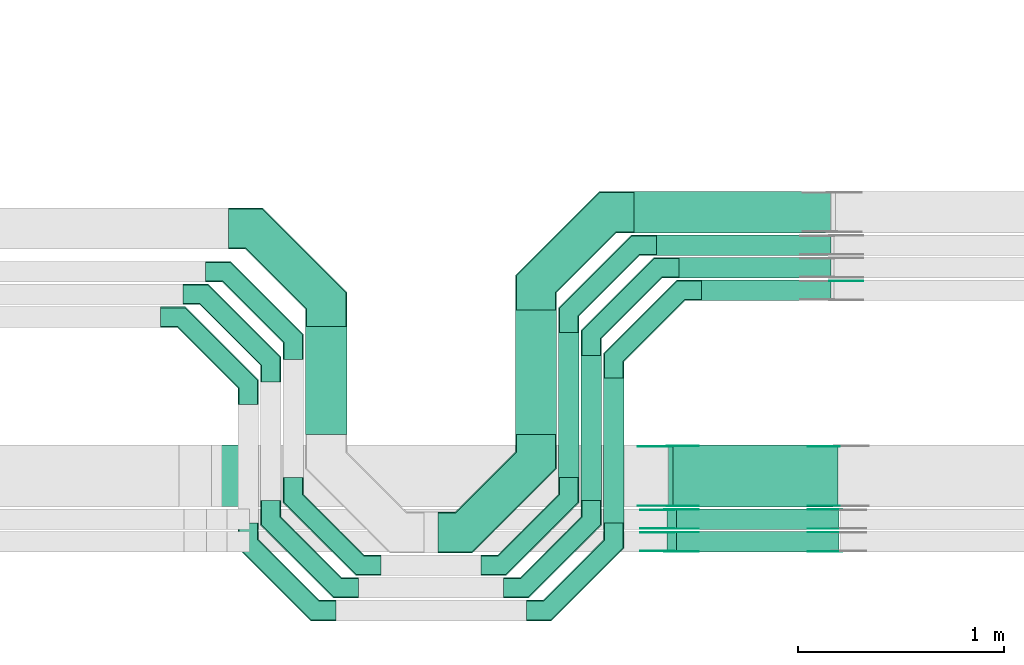
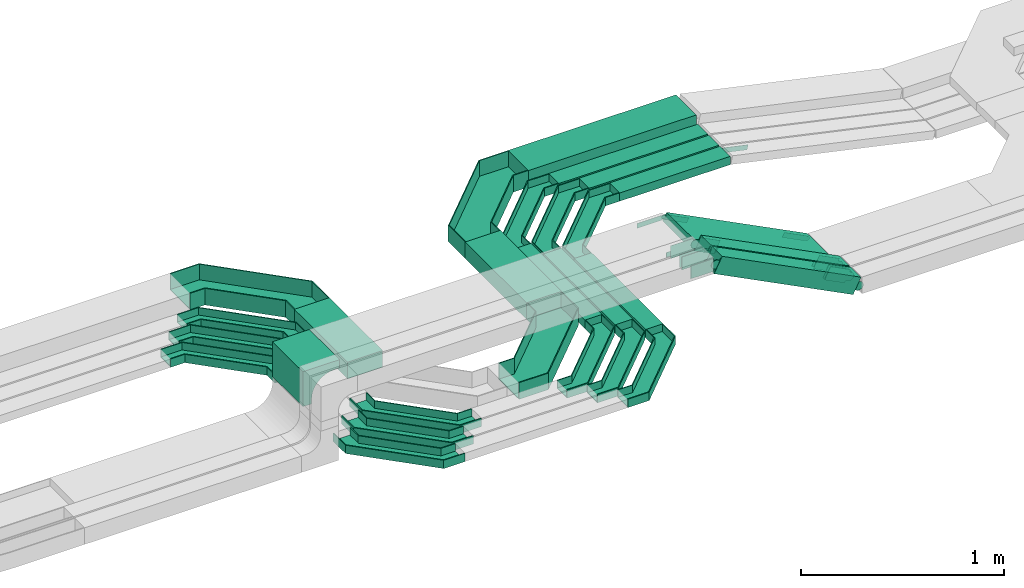
# One storey, part 14 of 32: 35 flow fittings, 12 flow segments.
"""IFC2X3 building model written with IfcOpenShell, lengths in millimetres."""

from ifc_helpers import new_model, entity, si_unit, converted_unit, derived_unit, direction, frame, frame_2d, origin, origin_2d_with_axis, place, context, subcontext, project, spatial, polyline, circle_curve, parameter, trimmed, segment, composite_curve, rectangle, outline, extrude, faceted_brep, source, transform, mapped, material, type_object, type_shapes, element, save


model = new_model("IFC2X3")

# Units and contexts
model_context = context("Model", 3, precision=0.01, world=origin(), true_north=direction((6.12303176911189e-17, 1.0)))
body_context = subcontext(model_context, "Body", "Model", "MODEL_VIEW")
ifc_project = project(units=[si_unit("LENGTHUNIT", "METRE", prefix="MILLI"), si_unit("AREAUNIT", "SQUARE_METRE"), si_unit("VOLUMEUNIT", "CUBIC_METRE"), converted_unit("PLANEANGLEUNIT", "DEGREE", entity("IfcRatioMeasure", 0.0174532925199433), si_unit("PLANEANGLEUNIT", "RADIAN"), dimensions=[0, 0, 0, 0, 0, 0, 0]), si_unit("MASSUNIT", "GRAM", prefix="KILO"), derived_unit("MASSDENSITYUNIT", [(si_unit("MASSUNIT", "GRAM", prefix="KILO"), 1), (si_unit("LENGTHUNIT", "METRE"), -3)]), derived_unit("MOMENTOFINERTIAUNIT", [(si_unit("LENGTHUNIT", "METRE"), 4)]), si_unit("TIMEUNIT", "SECOND"), si_unit("FREQUENCYUNIT", "HERTZ"), si_unit("THERMODYNAMICTEMPERATUREUNIT", "DEGREE_CELSIUS"), derived_unit("THERMALTRANSMITTANCEUNIT", [(si_unit("MASSUNIT", "GRAM", prefix="KILO"), 1), (si_unit("THERMODYNAMICTEMPERATUREUNIT", "KELVIN"), -1), (si_unit("TIMEUNIT", "SECOND"), -3)]), derived_unit("VOLUMETRICFLOWRATEUNIT", [(si_unit("LENGTHUNIT", "METRE"), 3), (si_unit("TIMEUNIT", "SECOND"), -1)]), derived_unit("MASSFLOWRATEUNIT", [(si_unit("MASSUNIT", "GRAM", prefix="KILO"), 1), (si_unit("TIMEUNIT", "SECOND"), -1)]), derived_unit("ROTATIONALFREQUENCYUNIT", [(si_unit("TIMEUNIT", "SECOND"), -1)]), si_unit("ELECTRICCURRENTUNIT", "AMPERE"), si_unit("ELECTRICVOLTAGEUNIT", "VOLT"), si_unit("POWERUNIT", "WATT"), si_unit("FORCEUNIT", "NEWTON", prefix="KILO"), si_unit("ILLUMINANCEUNIT", "LUX"), si_unit("LUMINOUSFLUXUNIT", "LUMEN"), si_unit("LUMINOUSINTENSITYUNIT", "CANDELA"), derived_unit("USERDEFINED", [(si_unit("MASSUNIT", "GRAM", prefix="KILO"), -1), (si_unit("LENGTHUNIT", "METRE"), -2), (si_unit("TIMEUNIT", "SECOND"), 3), (si_unit("LUMINOUSFLUXUNIT", "LUMEN"), 1)]), derived_unit("LINEARVELOCITYUNIT", [(si_unit("LENGTHUNIT", "METRE"), 1), (si_unit("TIMEUNIT", "SECOND"), -1)]), si_unit("PRESSUREUNIT", "PASCAL"), derived_unit("USERDEFINED", [(si_unit("LENGTHUNIT", "METRE"), -2), (si_unit("MASSUNIT", "GRAM", prefix="KILO"), 1), (si_unit("TIMEUNIT", "SECOND"), -2)]), derived_unit("LINEARFORCEUNIT", [(si_unit("MASSUNIT", "GRAM", prefix="KILO"), 1), (si_unit("LENGTHUNIT", "METRE"), 1), (si_unit("TIMEUNIT", "SECOND"), -2), (si_unit("LENGTHUNIT", "METRE"), -1)]), derived_unit("PLANARFORCEUNIT", [(si_unit("MASSUNIT", "GRAM", prefix="KILO"), 1), (si_unit("LENGTHUNIT", "METRE"), 1), (si_unit("TIMEUNIT", "SECOND"), -2), (si_unit("LENGTHUNIT", "METRE"), -2)])], contexts=[model_context])

# Site, building, storey
site_placement = place(None, origin())
site = spatial("IfcSite", under=ifc_project, at=site_placement, CompositionType="ELEMENT")
building_placement = place(site_placement, origin())
building = spatial("IfcBuilding", under=site, at=building_placement, CompositionType="ELEMENT")
storey_placement = place(building_placement, frame((0.0, 0.0, 8100.0)))
storey = spatial("IfcBuildingStorey", under=building, at=storey_placement, CompositionType="ELEMENT", Elevation=8100.0)

# Flow segments
cable_carrier_segment_type = type_object("IfcCableCarrierSegmentType", PredefinedType="CABLETRAYSEGMENT")
flow_segment_1_placement = place(storey_placement, frame((29971.47, 8994.02, 2800.0)))
element("IfcFlowSegment", 1, at=flow_segment_1_placement, inside=storey, type_object=cable_carrier_segment_type, context=body_context, shape_type="SweptSolid", body=[
    extrude(rectangle(XDim=524.980554870058, YDim=199.999999999998, at=origin_2d_with_axis()), frame((100.0, 262.49, 0.0), z_axis=(0.0, 0.0, 1.0), x_axis=(0.0, 1.0, 0.0)), (0.0, 0.0, 1.0), 99.9999999999989),
])
flow_segment_2_placement = place(storey_placement, frame((31200.78, 8784.02, 2800.0)))
element("IfcFlowSegment", 2, at=flow_segment_2_placement, inside=storey, type_object=cable_carrier_segment_type, context=body_context, shape_type="SweptSolid", body=[
    extrude(rectangle(XDim=704.980554870133, YDim=100.000000000003, at=origin_2d_with_axis()), frame((50.0, 352.49, 0.0), z_axis=(0.0, 0.0, 1.0), x_axis=(0.0, 1.0, 0.0)), (0.0, 0.0, 1.0), 50.0000000000016),
])
flow_segment_3_placement = place(storey_placement, frame((31310.31, 8674.49, 2800.0)))
element("IfcFlowSegment", 3, at=flow_segment_3_placement, inside=storey, type_object=cable_carrier_segment_type, context=body_context, shape_type="SweptSolid", body=[
    extrude(rectangle(XDim=704.50391172545, YDim=100.000000000003, at=origin_2d_with_axis()), frame((50.0, 352.25, 0.0), z_axis=(0.0, 0.0, 1.0), x_axis=(0.0, 1.0, 0.0)), (0.0, 0.0, 1.0), 50.0000000000016),
])
flow_segment_4_placement = place(storey_placement, frame((31420.31, 8564.49, 2800.0)))
element("IfcFlowSegment", 4, at=flow_segment_4_placement, inside=storey, type_object=cable_carrier_segment_type, context=body_context, shape_type="SweptSolid", body=[
    extrude(rectangle(XDim=704.50391172544, YDim=100.000000000003, at=origin_2d_with_axis()), frame((50.0, 352.25, 0.0), z_axis=(0.0, 0.0, 1.0), x_axis=(0.0, 1.0, 0.0)), (0.0, 0.0, 1.0), 50.0000000000016),
])
flow_segment_5_placement = place(storey_placement, frame((30990.78, 8994.02, 2800.0)))
element("IfcFlowSegment", 5, at=flow_segment_5_placement, inside=storey, type_object=cable_carrier_segment_type, context=body_context, shape_type="SweptSolid", body=[
    extrude(rectangle(XDim=604.980554870236, YDim=199.999999999998, at=origin_2d_with_axis()), frame((100.0, 302.49, 0.0), z_axis=(0.0, 0.0, 1.0), x_axis=(0.0, 1.0, 0.0)), (0.0, 0.0, 1.0), 99.9999999999989),
])
flow_segment_6_placement = place(storey_placement, frame((31676.78, 9865.0, 2800.0)))
element("IfcFlowSegment", 6, at=flow_segment_6_placement, inside=storey, type_object=cable_carrier_segment_type, context=body_context, shape_type="SweptSolid", body=[
    extrude(rectangle(XDim=849.378940105925, YDim=99.9999999999989, at=origin_2d_with_axis()), frame((424.69, 50.0, 0.0)), (0.0, 0.0, 1.0), 50.0000000000038),
])
flow_segment_7_placement = place(storey_placement, frame((31786.31, 9755.0, 2800.0)))
element("IfcFlowSegment", 7, at=flow_segment_7_placement, inside=storey, type_object=cable_carrier_segment_type, context=body_context, shape_type="SweptSolid", body=[
    extrude(rectangle(XDim=739.872366553705, YDim=99.9999999999989, at=origin_2d_with_axis()), frame((369.94, 50.0, 0.0)), (0.0, 0.0, 1.0), 50.0000000000016),
])
flow_segment_8_placement = place(storey_placement, frame((31896.31, 9645.0, 2800.0)))
element("IfcFlowSegment", 8, at=flow_segment_8_placement, inside=storey, type_object=cable_carrier_segment_type, context=body_context, shape_type="SweptSolid", body=[
    extrude(rectangle(XDim=629.876149019233, YDim=100.000000000001, at=origin_2d_with_axis()), frame((314.94, 50.0, 0.0)), (0.0, 0.0, 1.0), 50.0000000000016),
])
flow_segment_9_placement = place(storey_placement, frame((31566.78, 9975.0, 2800.0)))
element("IfcFlowSegment", 9, at=flow_segment_9_placement, inside=storey, type_object=cable_carrier_segment_type, context=body_context, shape_type="SweptSolid", body=[
    extrude(rectangle(XDim=956.723623030227, YDim=200.000000000002, at=origin_2d_with_axis()), frame((478.36, 100.0, 0.0)), (0.0, 0.0, 1.0), 99.9999999999968),
])
flow_segment_10_placement = place(storey_placement, frame((31729.22, 8422.45, 2761.05)))
element("IfcFlowSegment", 10, at=flow_segment_10_placement, inside=storey, type_object=cable_carrier_segment_type, context=body_context, shape_type="SweptSolid", body=[
    extrude(rectangle(XDim=99.9999999999994, YDim=99.9999999999989, at=origin_2d_with_axis()), frame((22.68, 50.0, 446.93), z_axis=(0.891238132843751, 0.0, -0.453535655230307), x_axis=(0.453535655230307, 0.0, 0.891238132843751)), (0.0, 0.0, 1.0), 887.170605116738),
])
flow_segment_11_placement = place(storey_placement, frame((31729.22, 8532.45, 2761.78)))
element("IfcFlowSegment", 11, at=flow_segment_11_placement, inside=storey, type_object=cable_carrier_segment_type, context=body_context, shape_type="SweptSolid", body=[
    extrude(rectangle(XDim=100.000000000002, YDim=99.9999999999989, at=origin_2d_with_axis()), frame((22.68, 50.0, 446.92), z_axis=(0.891242858773367, 0.0, -0.453526368236155), x_axis=(0.453526368236155, 0.0, 0.891242858773367)), (0.0, 0.0, 1.0), 887.166347895878),
])
flow_segment_12_placement = place(storey_placement, frame((31735.21, 8642.05, 2756.34)))
element("IfcFlowSegment", 12, at=flow_segment_12_placement, inside=storey, type_object=cable_carrier_segment_type, context=body_context, shape_type="SweptSolid", body=[
    extrude(rectangle(XDim=49.9999999999983, YDim=300.000000000001, at=origin_2d_with_axis()), frame((11.34, 150.0, 430.07), z_axis=(0.891245577775935, 0.0, -0.453521024975513), x_axis=(0.453521024975513, 0.0, 0.891245577775935)), (0.0, 0.0, 1.0), 899.153907455076),
])

# Flow fittings
ifc_material_1 = material()
cable_carrier_fitting_type_1 = type_object("IfcCableCarrierFittingType", Name="470_DKC_G5_Sheet horizontal bend:-", PredefinedType="NOTDEFINED", material=ifc_material_1)
shared_shape_1 = source(origin(), body_context, "Body", "Brep", [
    faceted_brep([(-476.0, -100.0, -50.0), (-476.0, -100.0, 50.0), (-476.0, -95.0, 50.0), (-476.0, -95.0, -45.0), (-476.0, 95.0, -45.0), (-476.0, 95.0, 50.0), (-476.0, 100.0, 50.0), (-476.0, 100.0, -50.0), (100.0, 476.0, -50.0), (-100.0, 476.0, -50.0), (-100.0, 476.0, 50.0), (-95.0, 476.0, 50.0), (-95.0, 476.0, -45.0), (95.0, 476.0, -45.0), (95.0, 476.0, 50.0), (100.0, 476.0, 50.0), (-308.58, -100.0, -50.0), (-308.58, -100.0, 50.0), (100.0, 308.58, 50.0), (95.0, 310.65, 50.0), (-310.65, -95.0, 50.0), (-310.65, -95.0, -45.0), (95.0, 310.65, -45.0), (-95.0, 389.35, -45.0), (-389.35, 95.0, -45.0), (-389.35, 95.0, 50.0), (-95.0, 389.35, 50.0), (-100.0, 391.42, 50.0), (-391.42, 100.0, 50.0), (-391.42, 100.0, -50.0), (-100.0, 391.42, -50.0), (100.0, 308.58, -50.0)], [[[0, 1, 2, 3, 4, 5, 6, 7]], [[8, 9, 10, 11, 12, 13, 14, 15]], [[1, 0, 16, 17]], [[2, 1, 17, 18, 15, 14, 19, 20]], [[3, 2, 20, 21]], [[4, 3, 21, 22, 13, 12, 23, 24]], [[5, 4, 24, 25]], [[6, 5, 25, 26, 11, 10, 27, 28]], [[7, 6, 28, 29]], [[0, 7, 29, 30, 9, 8, 31, 16]], [[17, 16, 31, 18]], [[21, 20, 19, 22]], [[25, 24, 23, 26]], [[29, 28, 27, 30]], [[18, 31, 8, 15]], [[22, 19, 14, 13]], [[26, 23, 12, 11]], [[30, 27, 10, 9]]]),
])
type_shapes(cable_carrier_fitting_type_1, [shared_shape_1])
flow_fitting_1_placement = place(storey_placement, frame((30071.47, 9995.0, 2850.0), z_axis=(0.0, 0.0, 1.0), x_axis=(0.0, 1.0, 0.0)))
element("IfcFlowFitting", 13, at=flow_fitting_1_placement, inside=storey, type_object=cable_carrier_fitting_type_1, material=ifc_material_1, Name="470_DKC_G5_Sheet horizontal bend:-", ObjectType="470_DKC_G5_Sheet horizontal bend:-", context=body_context, shape_type="MappedRepresentation", body=[
    mapped(shared_shape_1, transform((0.0, 0.0, 0.0), scale=1.0)),
])
flow_fitting_2_placement = place(storey_placement, frame((31090.78, 8518.02, 2850.0)))
element("IfcFlowFitting", 14, at=flow_fitting_2_placement, inside=storey, type_object=cable_carrier_fitting_type_1, material=ifc_material_1, Name="470_DKC_G5_Sheet horizontal bend:-", ObjectType="470_DKC_G5_Sheet horizontal bend:-", context=body_context, shape_type="MappedRepresentation", body=[
    mapped(shared_shape_1, transform((0.0, 0.0, 0.0), scale=1.0)),
])
flow_fitting_3_placement = place(storey_placement, frame((31090.78, 10075.0, 2850.0), z_axis=(0.0, 0.0, 1.0), x_axis=(-1.0, 0.0, 0.0)))
element("IfcFlowFitting", 15, at=flow_fitting_3_placement, inside=storey, type_object=cable_carrier_fitting_type_1, material=ifc_material_1, Name="470_DKC_G5_Sheet horizontal bend:-", ObjectType="470_DKC_G5_Sheet horizontal bend:-", context=body_context, shape_type="MappedRepresentation", body=[
    mapped(shared_shape_1, transform((0.0, 0.0, 0.0), scale=1.0)),
])
cable_carrier_fitting_type_2 = type_object("IfcCableCarrierFittingType", Name="470_DKC_G5_Sheet horizontal bend:-", PredefinedType="NOTDEFINED", material=ifc_material_1)
shared_shape_2 = source(origin(), body_context, "Body", "Brep", [
    faceted_brep([(-426.0, -50.0, -25.0), (-426.0, -50.0, 25.0), (-426.0, -45.0, 25.0), (-426.0, -45.0, -20.0), (-426.0, 45.0, -20.0), (-426.0, 45.0, 25.0), (-426.0, 50.0, 25.0), (-426.0, 50.0, -25.0), (50.0, 426.0, -25.0), (-50.0, 426.0, -25.0), (-50.0, 426.0, 25.0), (-45.0, 426.0, 25.0), (-45.0, 426.0, -20.0), (45.0, 426.0, -20.0), (45.0, 426.0, 25.0), (50.0, 426.0, 25.0), (-304.29, -50.0, -25.0), (-304.29, -50.0, 25.0), (50.0, 304.29, 25.0), (45.0, 306.36, 25.0), (-306.36, -45.0, 25.0), (-306.36, -45.0, -20.0), (45.0, 306.36, -20.0), (-45.0, 343.64, -20.0), (-343.64, 45.0, -20.0), (-343.64, 45.0, 25.0), (-45.0, 343.64, 25.0), (-50.0, 345.71, 25.0), (-345.71, 50.0, 25.0), (-345.71, 50.0, -25.0), (-50.0, 345.71, -25.0), (50.0, 304.29, -25.0)], [[[0, 1, 2, 3, 4, 5, 6, 7]], [[8, 9, 10, 11, 12, 13, 14, 15]], [[1, 0, 16, 17]], [[2, 1, 17, 18, 15, 14, 19, 20]], [[3, 2, 20, 21]], [[4, 3, 21, 22, 13, 12, 23, 24]], [[5, 4, 24, 25]], [[6, 5, 25, 26, 11, 10, 27, 28]], [[7, 6, 28, 29]], [[0, 7, 29, 30, 9, 8, 31, 16]], [[17, 16, 31, 18]], [[21, 20, 19, 22]], [[25, 24, 23, 26]], [[29, 28, 27, 30]], [[18, 31, 8, 15]], [[22, 19, 14, 13]], [[26, 23, 12, 11]], [[30, 27, 10, 9]]]),
])
type_shapes(cable_carrier_fitting_type_2, [shared_shape_2])
for number, where, z_axis, x_axis, name in (
    (16, (29691.95, 9565.48, 2825.0), (0.0, 0.0, 1.0), (0.0, 1.0, 0.0), "470_DKC_G5_Sheet horizontal bend:-"),
    (17, (29801.95, 9675.48, 2825.0), (0.0, 0.0, 1.0), (0.0, 1.0, 0.0), "470_DKC_G5_Sheet horizontal bend:-"),
    (18, (29911.47, 9785.0, 2825.0), (0.0, 0.0, 1.0), (0.0, 1.0, 0.0), "470_DKC_G5_Sheet horizontal bend:-"),
    (19, (29911.47, 8358.02, 2825.0), (0.0, 0.0, 1.0), (0.0, -1.0, 0.0), "470_DKC_G5_Sheet horizontal bend:-"),
):
    element("IfcFlowFitting", number, at=place(storey_placement, frame(where, z_axis=z_axis, x_axis=x_axis)), inside=storey, type_object=cable_carrier_fitting_type_2, material=ifc_material_1, Name=name, ObjectType="470_DKC_G5_Sheet horizontal bend:-", context=body_context, shape_type="MappedRepresentation", body=[
        mapped(shared_shape_2, transform((0.0, 0.0, 0.0), scale=1.0)),
    ])
flow_fitting_4_placement = place(storey_placement, frame((31250.78, 8358.02, 2825.0)))
element("IfcFlowFitting", 20, at=flow_fitting_4_placement, inside=storey, type_object=cable_carrier_fitting_type_2, material=ifc_material_1, Name="470_DKC_G5_Sheet horizontal bend:-", ObjectType="470_DKC_G5_Sheet horizontal bend:-", context=body_context, shape_type="MappedRepresentation", body=[
    mapped(shared_shape_2, transform((0.0, 0.0, 0.0), scale=1.0)),
])
flow_fitting_5_placement = place(storey_placement, frame((29801.95, 8248.49, 2825.0), z_axis=(0.0, 0.0, 1.0), x_axis=(0.0, -1.0, 0.0)))
element("IfcFlowFitting", 21, at=flow_fitting_5_placement, inside=storey, type_object=cable_carrier_fitting_type_2, material=ifc_material_1, Name="470_DKC_G5_Sheet horizontal bend:-", ObjectType="470_DKC_G5_Sheet horizontal bend:-", context=body_context, shape_type="MappedRepresentation", body=[
    mapped(shared_shape_2, transform((0.0, 0.0, 0.0), scale=1.0)),
])
flow_fitting_6_placement = place(storey_placement, frame((31360.31, 8248.49, 2825.0)))
element("IfcFlowFitting", 22, at=flow_fitting_6_placement, inside=storey, type_object=cable_carrier_fitting_type_2, material=ifc_material_1, Name="470_DKC_G5_Sheet horizontal bend:-", ObjectType="470_DKC_G5_Sheet horizontal bend:-", context=body_context, shape_type="MappedRepresentation", body=[
    mapped(shared_shape_2, transform((0.0, 0.0, 0.0), scale=1.0)),
])
flow_fitting_7_placement = place(storey_placement, frame((29691.95, 8138.49, 2825.0), z_axis=(0.0, 0.0, 1.0), x_axis=(0.0, -1.0, 0.0)))
element("IfcFlowFitting", 23, at=flow_fitting_7_placement, inside=storey, type_object=cable_carrier_fitting_type_2, material=ifc_material_1, Name="470_DKC_G5_Sheet horizontal bend:-", ObjectType="470_DKC_G5_Sheet horizontal bend:-", context=body_context, shape_type="MappedRepresentation", body=[
    mapped(shared_shape_2, transform((0.0, 0.0, 0.0), scale=1.0)),
])
flow_fitting_8_placement = place(storey_placement, frame((31470.31, 8138.49, 2825.0)))
element("IfcFlowFitting", 24, at=flow_fitting_8_placement, inside=storey, type_object=cable_carrier_fitting_type_2, material=ifc_material_1, Name="470_DKC_G5_Sheet horizontal bend:-", ObjectType="470_DKC_G5_Sheet horizontal bend:-", context=body_context, shape_type="MappedRepresentation", body=[
    mapped(shared_shape_2, transform((0.0, 0.0, 0.0), scale=1.0)),
])
for number, where, z_axis, x_axis, name in (
    (25, (31250.78, 9915.0, 2825.0), (0.0, 0.0, 1.0), (-1.0, 0.0, 0.0), "470_DKC_G5_Sheet horizontal bend:-"),
    (26, (31360.31, 9805.0, 2825.0), (0.0, 0.0, 1.0), (-1.0, 0.0, 0.0), "470_DKC_G5_Sheet horizontal bend:-"),
    (27, (31470.31, 9695.0, 2825.0), (0.0, 0.0, 1.0), (-1.0, 0.0, 0.0), "470_DKC_G5_Sheet horizontal bend:-"),
):
    element("IfcFlowFitting", number, at=place(storey_placement, frame(where, z_axis=z_axis, x_axis=x_axis)), inside=storey, type_object=cable_carrier_fitting_type_2, material=ifc_material_1, Name=name, ObjectType="470_DKC_G5_Sheet horizontal bend:-", context=body_context, shape_type="MappedRepresentation", body=[
        mapped(shared_shape_2, transform((0.0, 0.0, 0.0), scale=1.0)),
    ])
cable_carrier_fitting_type_3 = type_object("IfcCableCarrierFittingType", Name="470_DKC_S5_CDV 90 external vertical angle:-", PredefinedType="NOTDEFINED", material=ifc_material_1)
shared_shape_3 = source(origin(), body_context, "Body", "SweptSolid", [
    extrude(outline(composite_curve([segment(polyline([(80.0, 50.0), (110.0, 50.0)]), True, "CONTINUOUS"), segment(polyline([(110.0, 50.0), (110.0, 100.0)]), True, "CONTINUOUS"), segment(polyline([(110.0, 100.0), (-100.0, 100.0)]), True, "CONTINUOUS"), segment(polyline([(-100.0, 100.0), (-100.0, -110.0)]), True, "CONTINUOUS"), segment(polyline([(-100.0, -110.0), (-50.0, -110.0)]), True, "CONTINUOUS"), segment(polyline([(-50.0, -110.0), (-50.0, -80.0)]), True, "CONTINUOUS"), segment(trimmed(circle_curve(frame_2d((80.0, -80.0), x_axis=(-1.0, 0.0)), 130.0), [parameter(270.0)], [parameter(2.54444374517082e-13)], True, "PARAMETER"), False, "CONTINUOUS")], self_intersect=False)), frame((-75.0, 75.0, -149.0), z_axis=(0.0, 0.0, 1.0), x_axis=(-1.0, 0.0, 0.0)), (0.0, 0.0, 1.0), 299.0),
])
type_shapes(cable_carrier_fitting_type_3, [shared_shape_3])
flow_fitting_9_placement = place(storey_placement, frame((29539.46, 8792.05, 3190.02), z_axis=(0.0, 1.0, 0.0), x_axis=(0.0, 0.0, 1.0)))
element("IfcFlowFitting", 28, at=flow_fitting_9_placement, inside=storey, type_object=cable_carrier_fitting_type_3, material=ifc_material_1, Name="470_DKC_S5_90 external vertical angle", ObjectType="470_DKC_S5_CDV 90 external vertical angle:-", context=body_context, shape_type="MappedRepresentation", body=[
    mapped(shared_shape_3, transform((0.0, 0.0, 0.0), scale=1.0)),
])
ifc_material_2 = material(Name="G")
cable_carrier_fitting_type_4 = type_object("IfcCableCarrierFittingType", PredefinedType="NOTDEFINED", material=ifc_material_2)
shared_shape_4 = source(origin(), body_context, "Body", "SweptSolid", [
    extrude(outline(composite_curve([segment(trimmed(circle_curve(frame_2d((-44.59, 0.0), x_axis=(1.0, 0.0)), 12.5), [parameter(90.0000000000007)], [parameter(270.0)], True, "PARAMETER"), True, "CONTINUOUS"), segment(polyline([(-44.59, -12.5), (-33.09, -12.5)]), True, "CONTINUOUS"), segment(polyline([(-33.09, -12.5), (-31.23, -14.5)]), True, "CONTINUOUS"), segment(polyline([(-31.23, -14.5), (108.91, -14.5)]), True, "CONTINUOUS"), segment(polyline([(108.91, -14.5), (108.91, 14.5)]), True, "CONTINUOUS"), segment(polyline([(108.91, 14.5), (-31.23, 14.5)]), True, "CONTINUOUS"), segment(polyline([(-31.23, 14.5), (-33.09, 12.5)]), True, "CONTINUOUS"), segment(polyline([(-33.09, 12.5), (-44.59, 12.5)]), True, "CONTINUOUS")], self_intersect=False)), frame((44.59, 0.0, 0.0), z_axis=(0.0, 0.0, -1.0), x_axis=(1.0, 0.0, 0.0)), (0.0, 0.0, -1.0), 2.0),
])
type_shapes(cable_carrier_fitting_type_4, [shared_shape_4])
flow_fitting_10_placement = place(storey_placement, frame((32530.31, 9740.46, 2825.0), z_axis=(0.0, 1.0, 0.0), x_axis=(0.977059422663225, 0.0, -0.212966862645354)))
element("IfcFlowFitting", 29, at=flow_fitting_10_placement, inside=storey, type_object=cable_carrier_fitting_type_4, material=ifc_material_2, context=body_context, shape_type="MappedRepresentation", body=[
    mapped(shared_shape_4, transform((0.0, 0.0, 0.0), scale=1.0)),
])
cable_carrier_fitting_type_5 = type_object("IfcCableCarrierFittingType", PredefinedType="NOTDEFINED", material=ifc_material_2)
type_shapes(cable_carrier_fitting_type_5, [shared_shape_4])
flow_fitting_11_placement = place(storey_placement, frame((32555.01, 8935.51, 2775.02), z_axis=(0.0, 1.0, 0.0), x_axis=(-0.891245577775967, 0.0, 0.453521024975451)))
element("IfcFlowFitting", 30, at=flow_fitting_11_placement, inside=storey, type_object=cable_carrier_fitting_type_5, material=ifc_material_2, context=body_context, shape_type="MappedRepresentation", body=[
    mapped(shared_shape_4, transform((0.0, 0.0, 0.0), scale=1.0)),
])
flow_fitting_12_placement = place(storey_placement, frame((31739.46, 8937.51, 3190.02), z_axis=(0.0, 1.0, 0.0), x_axis=(0.891245577778197, 0.0, -0.453521024971068)))
element("IfcFlowFitting", 31, at=flow_fitting_12_placement, inside=storey, type_object=cable_carrier_fitting_type_4, material=ifc_material_2, context=body_context, shape_type="MappedRepresentation", body=[
    mapped(shared_shape_4, transform((0.0, 0.0, 0.0), scale=1.0)),
])
flow_fitting_13_placement = place(storey_placement, frame((31739.46, 8648.59, 3190.02), z_axis=(0.0, -1.0, 0.0), x_axis=(-1.0, 0.0, 0.0)))
element("IfcFlowFitting", 32, at=flow_fitting_13_placement, inside=storey, type_object=cable_carrier_fitting_type_5, material=ifc_material_2, context=body_context, shape_type="MappedRepresentation", body=[
    mapped(shared_shape_4, transform((0.0, 0.0, 0.0), scale=1.0)),
])
cable_carrier_fitting_type_6 = type_object("IfcCableCarrierFittingType", PredefinedType="NOTDEFINED", material=ifc_material_2)
shared_shape_5 = source(origin(), body_context, "Body", "SweptSolid", [
    extrude(outline(composite_curve([segment(trimmed(circle_curve(frame_2d((-44.59, 0.0), x_axis=(1.0, 0.0)), 12.5), [parameter(90.0000000000007)], [parameter(270.0)], True, "PARAMETER"), True, "CONTINUOUS"), segment(polyline([(-44.59, -12.5), (-33.09, -12.5)]), True, "CONTINUOUS"), segment(polyline([(-33.09, -12.5), (-31.23, -14.5)]), True, "CONTINUOUS"), segment(polyline([(-31.23, -14.5), (108.91, -14.5)]), True, "CONTINUOUS"), segment(polyline([(108.91, -14.5), (108.91, 14.5)]), True, "CONTINUOUS"), segment(polyline([(108.91, 14.5), (-31.23, 14.5)]), True, "CONTINUOUS"), segment(polyline([(-31.23, 14.5), (-33.09, 12.5)]), True, "CONTINUOUS"), segment(polyline([(-33.09, 12.5), (-44.59, 12.5)]), True, "CONTINUOUS")], self_intersect=False)), frame((44.59, 0.0, 0.0)), (0.0, 0.0, 1.0), 2.0),
])
type_shapes(cable_carrier_fitting_type_6, [shared_shape_5])
flow_fitting_14_placement = place(storey_placement, frame((32555.01, 8648.59, 2775.02), z_axis=(0.0, -1.0, 0.0), x_axis=(-0.891245577775967, 0.0, 0.453521024975451)))
element("IfcFlowFitting", 33, at=flow_fitting_14_placement, inside=storey, type_object=cable_carrier_fitting_type_6, material=ifc_material_2, context=body_context, shape_type="MappedRepresentation", body=[
    mapped(shared_shape_5, transform((0.0, 0.0, 0.0), scale=1.0)),
])
cable_carrier_fitting_type_7 = type_object("IfcCableCarrierFittingType", PredefinedType="NOTDEFINED", material=ifc_material_2)
type_shapes(cable_carrier_fitting_type_7, [shared_shape_5])
flow_fitting_15_placement = place(storey_placement, frame((31739.46, 8646.59, 3190.02), z_axis=(0.0, -1.0, 0.0), x_axis=(0.891245577778197, 0.0, -0.453521024971068)))
element("IfcFlowFitting", 34, at=flow_fitting_15_placement, inside=storey, type_object=cable_carrier_fitting_type_7, material=ifc_material_2, context=body_context, shape_type="MappedRepresentation", body=[
    mapped(shared_shape_5, transform((0.0, 0.0, 0.0), scale=1.0)),
])
flow_fitting_16_placement = place(storey_placement, frame((31739.46, 8935.51, 3190.02), z_axis=(0.0, 1.0, 0.0), x_axis=(-1.0, 0.0, 0.0)))
element("IfcFlowFitting", 35, at=flow_fitting_16_placement, inside=storey, type_object=cable_carrier_fitting_type_6, material=ifc_material_2, context=body_context, shape_type="MappedRepresentation", body=[
    mapped(shared_shape_5, transform((0.0, 0.0, 0.0), scale=1.0)),
])
cable_carrier_fitting_type_8 = type_object("IfcCableCarrierFittingType", PredefinedType="NOTDEFINED", material=ifc_material_2)
shared_shape_6 = source(origin(), body_context, "Body", "SweptSolid", [
    extrude(outline(composite_curve([segment(trimmed(circle_curve(frame_2d((-41.47, 0.0), x_axis=(1.0, 0.0)), 25.0), [parameter(90.0000000000007)], [parameter(270.0)], True, "PARAMETER"), True, "CONTINUOUS"), segment(polyline([(-41.47, -25.0), (-29.97, -25.0)]), True, "CONTINUOUS"), segment(polyline([(-29.97, -25.0), (-28.1, -38.5)]), True, "CONTINUOUS"), segment(polyline([(-28.1, -38.5), (99.53, -38.5)]), True, "CONTINUOUS"), segment(polyline([(99.53, -38.5), (99.53, 38.5)]), True, "CONTINUOUS"), segment(polyline([(99.53, 38.5), (-28.1, 38.5)]), True, "CONTINUOUS"), segment(polyline([(-28.1, 38.5), (-29.97, 25.0)]), True, "CONTINUOUS"), segment(polyline([(-29.97, 25.0), (-41.47, 25.0)]), True, "CONTINUOUS")], self_intersect=False)), frame((41.47, 0.0, 0.0), z_axis=(0.0, 0.0, -1.0), x_axis=(1.0, 0.0, 0.0)), (0.0, 0.0, -1.0), 2.0),
])
type_shapes(cable_carrier_fitting_type_8, [shared_shape_6])
for number, where, z_axis, x_axis in (
    (36, (32555.01, 8517.91, 2799.28), (0.0, 1.0, 0.0), (-0.891238132843699, 0.0, 0.45353565523041)),
    (37, (32555.01, 8627.91, 2800.01), (0.0, 1.0, 0.0), (-0.891242858773305, 0.0, 0.453526368236277)),
    (38, (31739.46, 8517.91, 3214.3), (0.0, 1.0, 0.0), (0.891238132843699, 0.0, -0.45353565523041)),
):
    element("IfcFlowFitting", number, at=place(storey_placement, frame(where, z_axis=z_axis, x_axis=x_axis)), inside=storey, type_object=cable_carrier_fitting_type_8, material=ifc_material_2, context=body_context, shape_type="MappedRepresentation", body=[
        mapped(shared_shape_6, transform((0.0, 0.0, 0.0), scale=1.0)),
    ])
cable_carrier_fitting_type_9 = type_object("IfcCableCarrierFittingType", PredefinedType="NOTDEFINED", material=ifc_material_2)
type_shapes(cable_carrier_fitting_type_9, [shared_shape_6])
flow_fitting_17_placement = place(storey_placement, frame((31739.46, 8428.99, 3214.3), z_axis=(0.0, -1.0, 0.0), x_axis=(-1.0, 0.0, 0.0)))
element("IfcFlowFitting", 39, at=flow_fitting_17_placement, inside=storey, type_object=cable_carrier_fitting_type_9, material=ifc_material_2, context=body_context, shape_type="MappedRepresentation", body=[
    mapped(shared_shape_6, transform((0.0, 0.0, 0.0), scale=1.0)),
])
flow_fitting_18_placement = place(storey_placement, frame((31739.46, 8627.91, 3215.02), z_axis=(0.0, 1.0, 0.0), x_axis=(0.891242858773305, 0.0, -0.453526368236277)))
element("IfcFlowFitting", 40, at=flow_fitting_18_placement, inside=storey, type_object=cable_carrier_fitting_type_8, material=ifc_material_2, context=body_context, shape_type="MappedRepresentation", body=[
    mapped(shared_shape_6, transform((0.0, 0.0, 0.0), scale=1.0)),
])
flow_fitting_19_placement = place(storey_placement, frame((31739.46, 8538.99, 3215.02), z_axis=(0.0, -1.0, 0.0), x_axis=(-1.0, 0.0, 0.0)))
element("IfcFlowFitting", 41, at=flow_fitting_19_placement, inside=storey, type_object=cable_carrier_fitting_type_9, material=ifc_material_2, context=body_context, shape_type="MappedRepresentation", body=[
    mapped(shared_shape_6, transform((0.0, 0.0, 0.0), scale=1.0)),
])
cable_carrier_fitting_type_10 = type_object("IfcCableCarrierFittingType", PredefinedType="NOTDEFINED", material=ifc_material_2)
shared_shape_7 = source(origin(), body_context, "Body", "SweptSolid", [
    extrude(outline(composite_curve([segment(trimmed(circle_curve(frame_2d((-41.47, 0.0), x_axis=(1.0, 0.0)), 25.0), [parameter(90.0000000000007)], [parameter(270.0)], True, "PARAMETER"), True, "CONTINUOUS"), segment(polyline([(-41.47, -25.0), (-29.97, -25.0)]), True, "CONTINUOUS"), segment(polyline([(-29.97, -25.0), (-28.1, -38.5)]), True, "CONTINUOUS"), segment(polyline([(-28.1, -38.5), (99.53, -38.5)]), True, "CONTINUOUS"), segment(polyline([(99.53, -38.5), (99.53, 38.5)]), True, "CONTINUOUS"), segment(polyline([(99.53, 38.5), (-28.1, 38.5)]), True, "CONTINUOUS"), segment(polyline([(-28.1, 38.5), (-29.97, 25.0)]), True, "CONTINUOUS"), segment(polyline([(-29.97, 25.0), (-41.47, 25.0)]), True, "CONTINUOUS")], self_intersect=False)), frame((41.47, 0.0, 0.0)), (0.0, 0.0, 1.0), 2.0),
])
type_shapes(cable_carrier_fitting_type_10, [shared_shape_7])
for number, where, z_axis, x_axis in (
    (42, (32555.01, 8426.99, 2799.28), (0.0, -1.0, 0.0), (-0.891238132843699, 0.0, 0.45353565523041)),
    (43, (32555.01, 8536.99, 2800.01), (0.0, -1.0, 0.0), (-0.891242858773305, 0.0, 0.453526368236277)),
    (44, (31739.46, 8426.99, 3214.3), (0.0, -1.0, 0.0), (0.891238132843699, 0.0, -0.45353565523041)),
):
    element("IfcFlowFitting", number, at=place(storey_placement, frame(where, z_axis=z_axis, x_axis=x_axis)), inside=storey, type_object=cable_carrier_fitting_type_10, material=ifc_material_2, context=body_context, shape_type="MappedRepresentation", body=[
        mapped(shared_shape_7, transform((0.0, 0.0, 0.0), scale=1.0)),
    ])
cable_carrier_fitting_type_11 = type_object("IfcCableCarrierFittingType", PredefinedType="NOTDEFINED", material=ifc_material_2)
type_shapes(cable_carrier_fitting_type_11, [shared_shape_7])
flow_fitting_20_placement = place(storey_placement, frame((31739.46, 8515.91, 3214.3), z_axis=(0.0, 1.0, 0.0), x_axis=(-1.0, 0.0, 0.0)))
element("IfcFlowFitting", 45, at=flow_fitting_20_placement, inside=storey, type_object=cable_carrier_fitting_type_11, material=ifc_material_2, context=body_context, shape_type="MappedRepresentation", body=[
    mapped(shared_shape_7, transform((0.0, 0.0, 0.0), scale=1.0)),
])
flow_fitting_21_placement = place(storey_placement, frame((31739.46, 8536.99, 3215.02), z_axis=(0.0, -1.0, 0.0), x_axis=(0.891242858773305, 0.0, -0.453526368236277)))
element("IfcFlowFitting", 46, at=flow_fitting_21_placement, inside=storey, type_object=cable_carrier_fitting_type_10, material=ifc_material_2, context=body_context, shape_type="MappedRepresentation", body=[
    mapped(shared_shape_7, transform((0.0, 0.0, 0.0), scale=1.0)),
])
flow_fitting_22_placement = place(storey_placement, frame((31739.46, 8625.91, 3215.02), z_axis=(0.0, 1.0, 0.0), x_axis=(-1.0, 0.0, 0.0)))
element("IfcFlowFitting", 47, at=flow_fitting_22_placement, inside=storey, type_object=cable_carrier_fitting_type_11, material=ifc_material_2, context=body_context, shape_type="MappedRepresentation", body=[
    mapped(shared_shape_7, transform((0.0, 0.0, 0.0), scale=1.0)),
])

save(model, "model.ifc")
